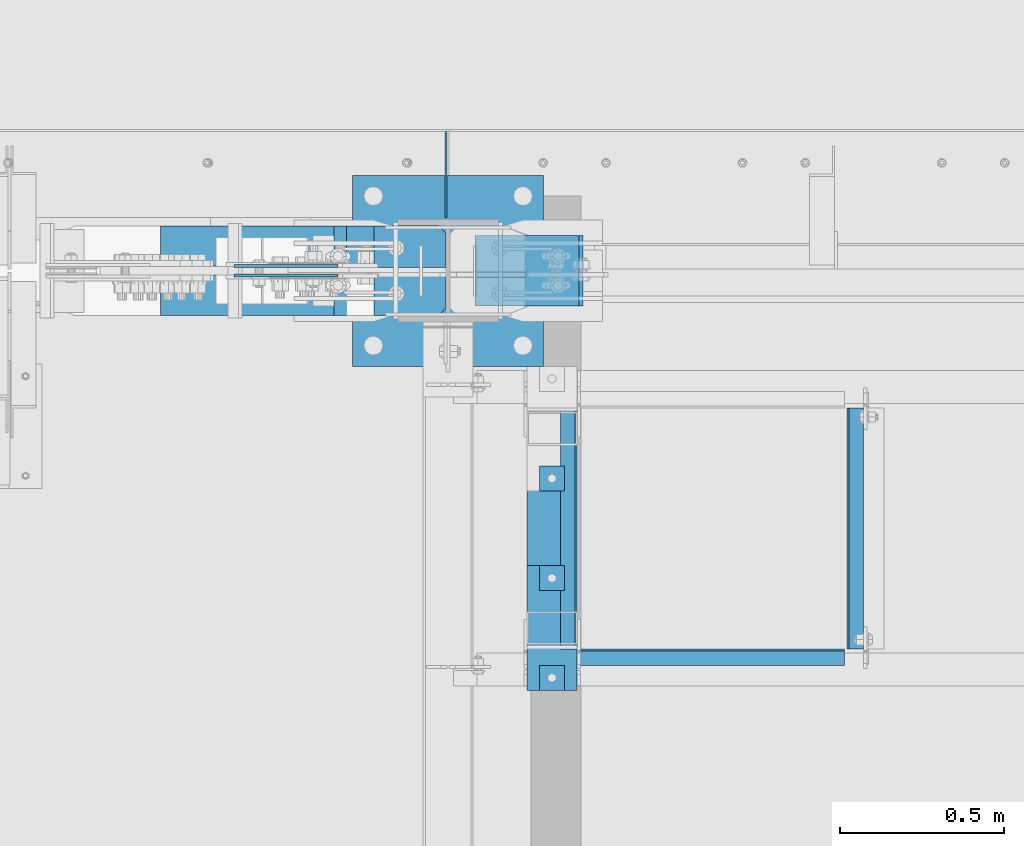
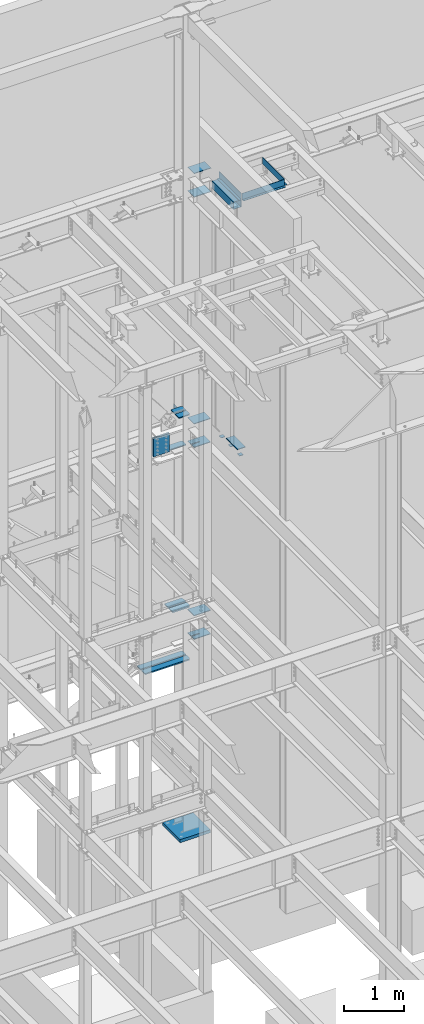
# One storey, part 927 of 1179: 25 beams, 13 elements without a shape of their own.
"""IFC2X3 building model written with IfcOpenShell, lengths in millimetres."""

from ifc_helpers import new_model, si_unit, frame, origin_with_axes, place, context, subcontext, project, spatial, faceted_brep, material, type_object, element, aggregate, save


model = new_model("IFC2X3")

# Units and contexts
model_context = context("Model", 3, precision=1e-05, world=origin_with_axes())
body_context = subcontext(model_context, "Body", "Model", "MODEL_VIEW")
ifc_project = project(units=[si_unit("LENGTHUNIT", "METRE", prefix="MILLI"), si_unit("AREAUNIT", "SQUARE_METRE"), si_unit("VOLUMEUNIT", "CUBIC_METRE"), si_unit("MASSUNIT", "GRAM", prefix="KILO"), si_unit("TIMEUNIT", "SECOND"), si_unit("PLANEANGLEUNIT", "RADIAN"), si_unit("SOLIDANGLEUNIT", "STERADIAN"), si_unit("THERMODYNAMICTEMPERATUREUNIT", "DEGREE_CELSIUS"), si_unit("LUMINOUSINTENSITYUNIT", "LUMEN")], contexts=[model_context])

# Site, building, storey
site_placement = place(None, origin_with_axes())
site = spatial("IfcSite", under=ifc_project, at=site_placement, CompositionType="ELEMENT")
building_placement = place(site_placement, origin_with_axes())
building = spatial("IfcBuilding", under=site, at=building_placement, Name="Undefined", CompositionType="ELEMENT")
storey_placement = place(building_placement, origin_with_axes())
storey = spatial("IfcBuildingStorey", under=building, at=storey_placement, Name="Undefined", CompositionType="ELEMENT", Elevation=0.0)

# Assembly, beam
assembly_1_placement = place(storey_placement, origin_with_axes())
assembly_1 = element("IfcElementAssembly", 1, at=assembly_1_placement, inside=storey, Name="BEAM", AssemblyPlace="NOTDEFINED", PredefinedType="RIGID_FRAME")
ifc_material_1 = material(Name="STEEL/A36")
beam_type_1 = type_object("IfcBeamType", PredefinedType="NOTDEFINED")
beam_1_placement = place(assembly_1_placement, frame((17681.575, 40411.4, 13252.4500061035), z_axis=(0.0, 1.0, 0.0), x_axis=(0.0, 0.0, -1.0)))
beam_1 = element("IfcBeam", 2, at=beam_1_placement, type_object=beam_type_1, material=ifc_material_1, Name="BENT_PLATE", context=body_context, shape_type="Brep", body=[
    faceted_brep([(0.0, -3.17499999999927, -368.300000000003), (0.0, -3.17499999999927, 368.300000000003), (0.0, 3.17499999999927, 368.300000000003), (0.0, 3.17499999999927, -368.300000000003), (133.350006103516, 3.17499999999927, 368.300000000003), (133.350006103516, 3.17499999999927, -368.300000000003), (127.000006103517, -3.17499999999927, -368.300000000003), (127.000006103517, -3.17499999999927, 368.300000000003), (133.350006103516, -47.625, 368.300000000003), (133.350006103516, -47.625, -368.300000000003), (127.000006103517, -47.625, 368.300000000003), (127.000006103517, -47.625, -368.300000000003)], [[[0, 1, 2, 3]], [[3, 2, 4, 5]], [[1, 0, 6, 7]], [[5, 4, 8, 9]], [[4, 2, 1, 7, 10, 8]], [[7, 6, 11, 10]], [[6, 0, 3, 5, 9, 11]], [[10, 11, 9, 8]]]),
])
aggregate(assembly_1, [beam_1])

assembly_2_placement = place(storey_placement, origin_with_axes())
assembly_2 = element("IfcElementAssembly", 3, at=assembly_2_placement, inside=storey, Name="BEAM", AssemblyPlace="NOTDEFINED", PredefinedType="RIGID_FRAME")
beam_2_placement = place(assembly_2_placement, frame((16849.725, 40411.4, 13252.4500061035), z_axis=(0.0, 1.0, 0.0), x_axis=(0.0, 0.0, -1.0)))
beam_2 = element("IfcBeam", 4, at=beam_2_placement, type_object=beam_type_1, material=ifc_material_1, Name="BENT_PLATE", context=body_context, shape_type="Brep", body=[
    faceted_brep([(0.0, -3.17499999999927, -368.300000000003), (0.0, -3.17499999999927, 368.300000000003), (0.0, 3.17499999999927, 368.300000000003), (0.0, 3.17499999999927, -368.300000000003), (127.000006103517, 3.17499999999927, 368.300000000003), (127.000006103517, 3.17499999999927, -368.300000000003), (133.350006103516, -3.17499999999927, -368.300000000003), (133.350006103516, -3.17499999999927, 368.300000000003), (127.000006103517, 47.625, 368.300000000003), (127.000006103517, 47.625, -368.300000000003), (133.350006103516, 47.625, 368.300000000003), (133.350006103516, 47.625, -368.300000000003)], [[[0, 1, 2, 3]], [[3, 2, 4, 5]], [[1, 0, 6, 7]], [[5, 4, 8, 9]], [[4, 2, 1, 7, 10, 8]], [[7, 6, 11, 10]], [[6, 0, 3, 5, 9, 11]], [[10, 11, 9, 8]]]),
])

assembly_3_placement = place(storey_placement, origin_with_axes())
assembly_3 = element("IfcElementAssembly", 5, at=assembly_3_placement, inside=storey, Name="BEAM", AssemblyPlace="NOTDEFINED", PredefinedType="RIGID_FRAME")
beam_3_placement = place(assembly_3_placement, frame((17265.65, 40039.925, 13252.4500061035), z_axis=(1.0, 0.0, 0.0), x_axis=(0.0, 0.0, -1.0)))
beam_3 = element("IfcBeam", 6, at=beam_3_placement, type_object=beam_type_1, material=ifc_material_1, Name="BENT_PLATE", context=body_context, shape_type="Brep", body=[
    faceted_brep([(0.0, -3.17500000000291, -406.400000000001), (0.0, -3.17500000000291, 406.400000000001), (0.0, 3.17500000000291, 406.400000000001), (0.0, 3.17500000000291, -406.400000000001), (133.350006103512, 3.17500000000291, 406.400000000001), (133.350006103512, 3.17500000000291, -406.400000000001), (127.000006103513, -3.17500000000291, -406.400000000001), (127.000006103513, -3.17500000000291, 406.400000000001), (133.350006103512, -47.625, 406.400000000001), (133.350006103512, -47.625, -406.400000000001), (127.000006103513, -47.625, 406.400000000001), (127.000006103513, -47.625, -406.400000000001)], [[[0, 1, 2, 3]], [[3, 2, 4, 5]], [[1, 0, 6, 7]], [[5, 4, 8, 9]], [[4, 2, 1, 7, 10, 8]], [[7, 6, 11, 10]], [[6, 0, 3, 5, 9, 11]], [[10, 11, 9, 8]]]),
])
aggregate(assembly_3, [beam_3])

assembly_4_placement = place(storey_placement, origin_with_axes())
assembly_4 = element("IfcElementAssembly", 7, at=assembly_4_placement, inside=storey, Name="EMBED PLATE", AssemblyPlace="NOTDEFINED", PredefinedType="RIGID_FRAME")
ifc_material_2 = material(Name="STEEL/A572-GR.50")
beam_type_2 = type_object("IfcBeamType", PredefinedType="NOTDEFINED")
beam_4_placement = place(assembly_4_placement, frame((16700.5, 40106.6, 8153.4), z_axis=(0.0, -1.0, 0.0), x_axis=(1.0, 0.0, 0.0)))
beam_4 = element("IfcBeam", 8, at=beam_4_placement, type_object=beam_type_2, material=ifc_material_2, Name="EMBED PLATE", context=body_context, shape_type="Brep", body=[
    faceted_brep([(0.0, 6.35000000000036, -190.5), (0.0, 6.35000000000036, 190.5), (152.400000000001, 6.35000000000036, 190.5), (152.400000000001, 6.35000000000036, -190.5), (0.0, -6.35000000000036, 190.5), (152.400000000001, -6.35000000000036, 190.5), (0.0, -6.35000000000036, -190.5), (152.400000000001, -6.35000000000036, -190.5)], [[[0, 1, 2, 3]], [[1, 4, 5, 2]], [[4, 6, 7, 5]], [[6, 0, 3, 7]], [[5, 7, 3, 2]], [[6, 4, 1, 0]]]),
])
aggregate(assembly_4, [beam_4])

# Assembly, beams
assembly_5_placement = place(storey_placement, origin_with_axes())
assembly_5 = element("IfcElementAssembly", 9, at=assembly_5_placement, inside=storey, Name="COLUMN", AssemblyPlace="NOTDEFINED", PredefinedType="RIGID_FRAME")
beam_type_3 = type_object("IfcBeamType", PredefinedType="NOTDEFINED")
beam_5_placement = place(assembly_5_placement, frame((16541.7500000316, 41198.8, 12646.0249999713), z_axis=(0.0, -1.0, 0.0), x_axis=(1.0, 0.0, 0.0)))
beam_5 = element("IfcBeam", 10, at=beam_5_placement, type_object=beam_type_3, material=ifc_material_2, Name="PLATE", context=body_context, shape_type="Brep", body=[
    faceted_brep([(0.0, 6.35000000000036, -107.949999999997), (0.0, 6.35000000000036, 107.949999999997), (330.200000043667, 6.35000000000036, 107.949999999997), (330.200000043667, 6.35000000000036, -107.949999999997), (0.0, -6.35000000000036, 107.949999999997), (330.200000043667, -6.35000000000036, 107.949999999997), (0.0, -6.35000000000036, -107.949999999997), (330.200000043667, -6.35000000000036, -107.949999999997)], [[[0, 1, 2, 3]], [[1, 4, 5, 2]], [[4, 6, 7, 5]], [[6, 0, 3, 7]], [[5, 7, 3, 2]], [[6, 4, 1, 0]]]),
])
beam_6_placement = place(assembly_5_placement, frame((16541.7500000328, 41198.8, 13125.4499999713), z_axis=(0.0, -1.0, 0.0), x_axis=(1.0, 0.0, 0.0)))
beam_6 = element("IfcBeam", 11, at=beam_6_placement, type_object=beam_type_3, material=ifc_material_2, Name="PLATE", context=body_context, shape_type="Brep", body=[
    faceted_brep([(0.0, 6.35000000000036, -107.949999999997), (0.0, 6.35000000000036, 107.949999999997), (330.200000043667, 6.35000000000036, 107.949999999997), (330.200000043667, 6.35000000000036, -107.949999999997), (0.0, -6.35000000000036, 107.949999999997), (330.200000043667, -6.35000000000036, 107.949999999997), (0.0, -6.35000000000036, -107.949999999997), (330.200000043667, -6.35000000000036, -107.949999999997)], [[[0, 1, 2, 3]], [[1, 4, 5, 2]], [[4, 6, 7, 5]], [[6, 0, 3, 7]], [[5, 7, 3, 2]], [[6, 4, 1, 0]]]),
])
beam_7_placement = place(assembly_5_placement, frame((16541.75, 41198.8, 7540.625), z_axis=(0.0, -1.0, 0.0), x_axis=(1.0, 0.0, 0.0)))
beam_7 = element("IfcBeam", 12, at=beam_7_placement, type_object=beam_type_3, material=ifc_material_2, Name="PLATE", context=body_context, shape_type="Brep", body=[
    faceted_brep([(0.0, -6.35000000000036, 19.8437500550863), (0.0, 6.35000000000036, 19.8437500550863), (150.812499998719, 6.35000000000036, 19.8437500546802), (150.812499998719, -6.35000000000036, 19.8437500546802), (153.850049742483, 6.35000000000036, 19.2395438442423), (153.850049742483, -6.35000000000036, 19.2395438442423), (156.425160073413, 6.35000000000036, 17.5189101313016), (156.425160073413, -6.35000000000036, 17.5189101313016), (158.145793787233, 6.35000000000036, 14.9437998009562), (158.145793787233, -6.35000000000036, 14.9437998009562), (150.812499998683, -6.35000000000036, 3.96875005468019), (150.812499998683, 6.35000000000036, 3.96875005468019), (0.0, 6.35000000000036, 3.96875005508628), (0.0, -6.35000000000036, 3.96875005508628), (153.850049743713, -6.35000000000036, 4.57295626562569), (153.850049743713, 6.35000000000036, 4.57295626562569), (156.42516007532, -6.35000000000036, 6.29358997996519), (156.42516007532, 6.35000000000036, 6.29358997996519), (158.14579378879, -6.35000000000036, 8.8687003121604), (158.14579378879, 6.35000000000036, 8.8687003121604), (158.749999998705, -6.35000000000036, 11.9062500573978), (158.749999998705, 6.35000000000036, 11.9062500573978), (0.0, 6.35000000000036, 107.949999999997), (0.0, -6.35000000000036, 107.949999999997), (317.5, -6.35000000000036, 107.949999999997), (317.5, 6.35000000000036, 107.949999999997), (317.5, -6.35000000000036, -107.949999999997), (317.5, 6.35000000000036, -107.949999999997), (0.0, -6.35000000000036, -107.949999999997), (0.0, 6.35000000000036, -107.949999999997)], [[[0, 1, 2, 3]], [[3, 2, 4, 5]], [[5, 4, 6, 7]], [[7, 6, 8, 9]], [[10, 11, 12, 13]], [[14, 15, 11, 10]], [[16, 17, 15, 14]], [[18, 19, 17, 16]], [[20, 21, 19, 18]], [[9, 8, 21, 20]], [[22, 23, 24, 25]], [[24, 26, 27, 25]], [[28, 29, 27, 26]], [[29, 28, 13, 12]], [[6, 4, 2, 1, 22, 25, 27, 29, 12, 11, 15, 17, 19, 21, 8]], [[23, 22, 1, 0]], [[16, 14, 10, 13, 28, 26, 24, 23, 0, 3, 5, 7, 9, 20, 18]]]),
])
beam_8_placement = place(assembly_5_placement, frame((16541.75, 41198.8, 8020.05), z_axis=(0.0, -1.0, 0.0), x_axis=(1.0, 0.0, 0.0)))
beam_8 = element("IfcBeam", 13, at=beam_8_placement, type_object=beam_type_3, material=ifc_material_2, Name="PLATE", context=body_context, shape_type="Brep", body=[
    faceted_brep([(0.0, 6.35000000000036, -107.949999999997), (0.0, 6.35000000000036, 107.949999999997), (317.5, 6.35000000000036, 107.949999999997), (317.5, 6.35000000000036, -107.949999999997), (0.0, -6.35000000000036, 107.949999999997), (317.5, -6.35000000000036, 107.949999999997), (0.0, -6.35000000000036, -107.949999999997), (317.5, -6.35000000000036, -107.949999999997)], [[[0, 1, 2, 3]], [[1, 4, 5, 2]], [[4, 6, 7, 5]], [[6, 0, 3, 7]], [[5, 7, 3, 2]], [[6, 4, 1, 0]]]),
])
beam_9_placement = place(assembly_5_placement, frame((16541.75, 41198.8, 3629.025), z_axis=(0.0, -1.0, 0.0), x_axis=(1.0, 0.0, 0.0)))
beam_9 = element("IfcBeam", 14, at=beam_9_placement, type_object=beam_type_3, material=ifc_material_2, Name="PLATE", context=body_context, shape_type="Brep", body=[
    faceted_brep([(0.0, -6.35000000000036, 19.8437500550863), (0.0, 6.35000000000036, 19.8437500550863), (150.812499998719, 6.35000000000036, 19.8437500546802), (150.812499998719, -6.35000000000036, 19.8437500546802), (153.850049742483, 6.35000000000036, 19.2395438442423), (153.850049742483, -6.35000000000036, 19.2395438442423), (156.425160073413, 6.35000000000036, 17.5189101313016), (156.425160073413, -6.35000000000036, 17.5189101313016), (158.145793787233, 6.35000000000036, 14.9437998009562), (158.145793787233, -6.35000000000036, 14.9437998009562), (150.812499998683, -6.35000000000036, 3.96875005468019), (150.812499998683, 6.35000000000036, 3.96875005468019), (0.0, 6.35000000000036, 3.96875005508628), (0.0, -6.35000000000036, 3.96875005508628), (153.850049743713, -6.35000000000036, 4.57295626562569), (153.850049743713, 6.35000000000036, 4.57295626562569), (156.42516007532, -6.35000000000036, 6.29358997996519), (156.42516007532, 6.35000000000036, 6.29358997996519), (158.14579378879, -6.35000000000036, 8.8687003121604), (158.14579378879, 6.35000000000036, 8.8687003121604), (158.749999998705, -6.35000000000036, 11.9062500573978), (158.749999998705, 6.35000000000036, 11.9062500573978), (0.0, 6.35000000000036, 107.949999999997), (0.0, -6.35000000000036, 107.949999999997), (317.5, -6.35000000000036, 107.949999999997), (317.5, 6.35000000000036, 107.949999999997), (317.5, -6.35000000000036, -107.949999999997), (317.5, 6.35000000000036, -107.949999999997), (0.0, -6.35000000000036, -107.949999999997), (0.0, 6.35000000000036, -107.949999999997)], [[[0, 1, 2, 3]], [[3, 2, 4, 5]], [[5, 4, 6, 7]], [[7, 6, 8, 9]], [[10, 11, 12, 13]], [[14, 15, 11, 10]], [[16, 17, 15, 14]], [[18, 19, 17, 16]], [[20, 21, 19, 18]], [[9, 8, 21, 20]], [[22, 23, 24, 25]], [[24, 26, 27, 25]], [[28, 29, 27, 26]], [[29, 28, 13, 12]], [[6, 4, 2, 1, 22, 25, 27, 29, 12, 11, 15, 17, 19, 21, 8]], [[23, 22, 1, 0]], [[16, 14, 10, 13, 28, 26, 24, 23, 0, 3, 5, 7, 9, 20, 18]]]),
])
beam_10_placement = place(assembly_5_placement, frame((16541.75, 41198.8, 4108.45), z_axis=(0.0, -1.0, 0.0), x_axis=(1.0, 0.0, 0.0)))
beam_10 = element("IfcBeam", 15, at=beam_10_placement, type_object=beam_type_3, material=ifc_material_2, Name="PLATE", context=body_context, shape_type="Brep", body=[
    faceted_brep([(0.0, 6.35000000000036, -107.949999999997), (0.0, 6.35000000000036, 107.949999999997), (317.5, 6.35000000000036, 107.949999999997), (317.5, 6.35000000000036, -107.949999999997), (0.0, -6.35000000000036, 107.949999999997), (317.5, -6.35000000000036, 107.949999999997), (0.0, -6.35000000000036, -107.949999999997), (317.5, -6.35000000000036, -107.949999999997)], [[[0, 1, 2, 3]], [[1, 4, 5, 2]], [[4, 6, 7, 5]], [[6, 0, 3, 7]], [[5, 7, 3, 2]], [[6, 4, 1, 0]]]),
])
beam_type_4 = type_object("IfcBeamType", PredefinedType="NOTDEFINED")
beam_11_placement = place(assembly_5_placement, frame((16148.0499999994, 41271.825, 7556.5), z_axis=(0.0, 1.0, 0.0), x_axis=(1.0, 0.0, 0.0)))
beam_11 = element("IfcBeam", 16, at=beam_11_placement, type_object=beam_type_4, material=ifc_material_2, Name="PLATE", context=body_context, shape_type="Brep", body=[
    faceted_brep([(304.800000000001, 9.52499999999964, 41.2750000000015), (282.575000000003, 9.52499999999964, 63.5), (282.575000000003, -9.52499999999964, 63.5), (304.800000000001, -9.52499999999964, 41.2750000000015), (304.800000000001, 9.52499999999964, -63.5), (0.0, 9.52500000000146, -63.5), (0.0, 9.52500000000146, 63.5), (0.0, -9.52500000000146, 63.5), (0.0, -9.52500000000146, -63.5), (304.800000000001, -9.52499999999964, -63.5)], [[[0, 1, 2, 3]], [[4, 5, 6, 1, 0]], [[6, 7, 2, 1]], [[7, 8, 9, 3, 2]], [[8, 5, 4, 9]], [[9, 4, 0, 3]], [[8, 7, 6, 5]]]),
])
beam_12_placement = place(assembly_5_placement, frame((16232.5906748554, 41125.775, 8263.92332782742), z_axis=(0.0, -1.0, 0.0), x_axis=(1.0, 0.0, 0.0)))
beam_12 = element("IfcBeam", 17, at=beam_12_placement, type_object=beam_type_4, material=ifc_material_2, Name="PLATE", context=body_context, shape_type="Brep", body=[
    faceted_brep([(220.259325144028, 9.52499999999964, 41.2750000000015), (198.03432514403, 9.52499999999964, 63.5), (198.03432514403, -9.52499999999964, 63.5), (220.259325144028, -9.52499999999964, 41.2750000000015), (220.259325144028, 9.52499999999964, -63.5), (0.0, 9.52500000000146, -63.5), (0.0, 9.52500000000146, 63.5), (0.0, -9.52500000000146, 63.5), (0.0, -9.52500000000146, -63.5), (220.259325144028, -9.52499999999964, -63.5)], [[[0, 1, 2, 3]], [[4, 5, 6, 1, 0]], [[6, 7, 2, 1]], [[7, 8, 9, 3, 2]], [[8, 5, 4, 9]], [[9, 4, 0, 3]], [[8, 7, 6, 5]]]),
])
beam_13_placement = place(assembly_5_placement, frame((16232.5906748554, 41271.825, 8263.92332782742), z_axis=(0.0, 1.0, 0.0), x_axis=(1.0, 0.0, 0.0)))
beam_13 = element("IfcBeam", 18, at=beam_13_placement, type_object=beam_type_4, material=ifc_material_2, Name="PLATE", context=body_context, shape_type="Brep", body=[
    faceted_brep([(220.259325144028, 9.52499999999964, 41.2750000000015), (198.03432514403, 9.52499999999964, 63.5), (198.03432514403, -9.52499999999964, 63.5), (220.259325144028, -9.52499999999964, 41.2750000000015), (220.259325144028, 9.52499999999964, -63.5), (0.0, 9.52500000000146, -63.5), (0.0, 9.52500000000146, 63.5), (0.0, -9.52500000000146, 63.5), (0.0, -9.52500000000146, -63.5), (220.259325144028, -9.52499999999964, -63.5)], [[[0, 1, 2, 3]], [[4, 5, 6, 1, 0]], [[6, 7, 2, 1]], [[7, 8, 9, 3, 2]], [[8, 5, 4, 9]], [[9, 4, 0, 3]], [[8, 7, 6, 5]]]),
])

# Assembly, beam
assembly_6_placement = place(storey_placement, origin_with_axes())
assembly_6 = element("IfcElementAssembly", 19, at=assembly_6_placement, inside=storey, Name="BEAM", AssemblyPlace="NOTDEFINED", PredefinedType="RIGID_FRAME")
beam_type_5 = type_object("IfcBeamType", PredefinedType="NOTDEFINED")
beam_14_placement = place(assembly_6_placement, frame((16452.8500000005, 41362.3124999949, 8083.55000610352), z_axis=(0.0, 0.0, 1.0), x_axis=(0.0, 1.0, 0.0)))
beam_14 = element("IfcBeam", 20, at=beam_14_placement, type_object=beam_type_5, material=ifc_material_1, Name="PLATE", context=body_context, shape_type="Brep", body=[
    faceted_brep([(261.937500000007, -3.17500000000001, -44.4500000000007), (242.887500000004, -3.17500000000001, -63.5), (242.887500000004, 3.17500000000001, -63.5), (261.937500000007, 3.17500000000001, -44.4500000000007), (0.0, 3.17499999999927, -63.5), (0.0, 3.17499999999927, 63.5), (261.937500000007, 3.17500000000001, 63.5), (0.0, -3.17499999999927, 63.5), (261.937500000007, -3.17500000000001, 63.5), (0.0, -3.17499999999927, -63.5)], [[[0, 1, 2, 3]], [[4, 5, 6, 3, 2]], [[5, 7, 8, 6]], [[8, 7, 9, 1, 0]], [[9, 4, 2, 1]], [[6, 8, 0, 3]], [[9, 7, 5, 4]]]),
])
aggregate(assembly_6, [beam_14])

assembly_7_placement = place(storey_placement, origin_with_axes())
assembly_7 = element("IfcElementAssembly", 21, at=assembly_7_placement, inside=storey, Name="PLATE", AssemblyPlace="NOTDEFINED", PredefinedType="RIGID_FRAME")
beam_type_6 = type_object("IfcBeamType", PredefinedType="NOTDEFINED")
beam_15_placement = place(assembly_7_placement, frame((16452.8508052372, 41123.3935, 3269.48771062712), z_axis=(0.0, 1.0, 0.0), x_axis=(-1.0, 0.0, 0.0)))
beam_15 = element("IfcBeam", 22, at=beam_15_placement, type_object=beam_type_6, material=ifc_material_2, Name="PLATE", context=body_context, shape_type="Brep", body=[
    faceted_brep([(22.2249999999985, -12.6999999999998, -61.1189999999997), (0.0, -12.6999999999998, -38.8940000000002), (0.0, 12.6999999999998, -38.8940000000002), (22.2249999999985, 12.6999999999998, -61.1189999999997), (0.0, 12.7, 61.1189999999988), (873.039458857706, 12.6999999999998, 61.1189999999988), (873.039458857706, 12.6999999999998, -61.1189999999988), (0.0, -12.7, 61.1189999999988), (873.039458857706, -12.6999999999998, 61.1189999999988), (873.039458857706, -12.6999999999998, -61.1189999999988)], [[[0, 1, 2, 3]], [[4, 5, 6, 3, 2]], [[4, 7, 8, 5]], [[9, 8, 7, 1, 0]], [[6, 9, 0, 3]], [[8, 9, 6, 5]], [[7, 4, 2, 1]]]),
])
aggregate(assembly_7, [beam_15])

assembly_8_placement = place(storey_placement, origin_with_axes())
assembly_8 = element("IfcElementAssembly", 23, at=assembly_8_placement, inside=storey, Name="PLATE", AssemblyPlace="NOTDEFINED", PredefinedType="RIGID_FRAME")
beam_16_placement = place(assembly_8_placement, frame((16452.8508052372, 41274.2065, 3269.48771062712), z_axis=(0.0, -1.0, 0.0), x_axis=(-1.0, 0.0, 0.0)))
beam_16 = element("IfcBeam", 24, at=beam_16_placement, type_object=beam_type_6, material=ifc_material_2, Name="PLATE", context=body_context, shape_type="Brep", body=[
    faceted_brep([(22.2249999999985, -12.6999999999998, -61.1189999999997), (0.0, -12.6999999999998, -38.8940000000002), (0.0, 12.6999999999998, -38.8940000000002), (22.2249999999985, 12.6999999999998, -61.1189999999997), (0.0, 12.7, 61.1189999999988), (873.039458857706, 12.6999999999998, 61.1189999999988), (873.039458857706, 12.6999999999998, -61.1189999999988), (0.0, -12.7, 61.1189999999988), (873.039458857706, -12.6999999999998, 61.1189999999988), (873.039458857706, -12.6999999999998, -61.1189999999988)], [[[0, 1, 2, 3]], [[4, 5, 6, 3, 2]], [[4, 7, 8, 5]], [[9, 8, 7, 1, 0]], [[6, 9, 0, 3]], [[8, 9, 6, 5]], [[7, 4, 2, 1]]]),
])
aggregate(assembly_8, [beam_16])

# Beam
beam_17_placement = place(assembly_5_placement, frame((16452.8508052832, 41123.3935, 4347.84110103117), z_axis=(0.0, 1.0, 0.0), x_axis=(-1.0, 0.0, 0.0)))
beam_17 = element("IfcBeam", 25, at=beam_17_placement, type_object=beam_type_6, material=ifc_material_2, Name="PLATE", context=body_context, shape_type="Brep", body=[
    faceted_brep([(22.2249999999985, -12.6999999999998, -61.1189999999997), (0.0, -12.6999999999998, -38.8940000000002), (0.0, 12.6999999999998, -38.8940000000002), (22.2249999999985, 12.6999999999998, -61.1189999999997), (0.0, 12.7, 61.1189999999988), (342.342939159009, 12.6999999999998, 61.1189999999988), (342.342939159009, 12.6999999999998, -61.1189999999988), (0.0, -12.7, 61.1189999999988), (342.342939159009, -12.6999999999998, 61.1189999999988), (342.342939159009, -12.6999999999998, -61.1189999999988)], [[[0, 1, 2, 3]], [[4, 5, 6, 3, 2]], [[4, 7, 8, 5]], [[9, 8, 7, 1, 0]], [[6, 9, 0, 3]], [[8, 9, 6, 5]], [[7, 4, 2, 1]]]),
])

beam_18_placement = place(assembly_5_placement, frame((16452.8508052832, 41274.2065, 4347.84110103117), z_axis=(0.0, -1.0, 0.0), x_axis=(-1.0, 0.0, 0.0)))
beam_18 = element("IfcBeam", 26, at=beam_18_placement, type_object=beam_type_6, material=ifc_material_2, Name="PLATE", context=body_context, shape_type="Brep", body=[
    faceted_brep([(22.2249999999985, -12.6999999999998, -61.1189999999997), (0.0, -12.6999999999998, -38.8940000000002), (0.0, 12.6999999999998, -38.8940000000002), (22.2249999999985, 12.6999999999998, -61.1189999999997), (0.0, 12.7, 61.1189999999988), (342.342939159009, 12.6999999999998, 61.1189999999988), (342.342939159009, 12.6999999999998, -61.1189999999988), (0.0, -12.7, 61.1189999999988), (342.342939159009, -12.6999999999998, 61.1189999999988), (342.342939159009, -12.6999999999998, -61.1189999999988)], [[[0, 1, 2, 3]], [[4, 5, 6, 3, 2]], [[4, 7, 8, 5]], [[9, 8, 7, 1, 0]], [[6, 9, 0, 3]], [[8, 9, 6, 5]], [[7, 4, 2, 1]]]),
])

# Assembly, beam
assembly_9_placement = place(storey_placement, origin_with_axes())
assembly_9 = element("IfcElementAssembly", 27, at=assembly_9_placement, inside=storey, Name="PLATE", AssemblyPlace="NOTDEFINED", PredefinedType="RIGID_FRAME")
beam_type_7 = type_object("IfcBeamType", PredefinedType="NOTDEFINED")
beam_19_placement = place(assembly_9_placement, frame((16122.3534855108, 41184.5127863882, 7739.06051692846), z_axis=(0.0, 0.0, -1.0), x_axis=(-1.0, 0.0, 0.0)))
beam_19 = element("IfcBeam", 28, at=beam_19_placement, type_object=beam_type_7, material=ifc_material_2, Name="PLATE", context=body_context, shape_type="Brep", body=[
    faceted_brep([(0.0, 4.76249999999709, -190.5), (0.0, 4.76249999999709, 190.5), (317.499999999995, 4.76250000000073, 190.500000000051), (317.500000000042, 4.76250000000073, -190.499999999973), (0.0, -4.76249999999709, 190.5), (317.499999999995, -4.76250000000073, 190.500000000051), (0.0, -4.76249999999709, -190.5), (317.500000000042, -4.76250000000073, -190.499999999973)], [[[0, 1, 2, 3]], [[1, 4, 5, 2]], [[4, 6, 7, 5]], [[6, 0, 3, 7]], [[5, 7, 3, 2]], [[6, 4, 1, 0]]]),
])
aggregate(assembly_9, [beam_19])

assembly_10_placement = place(storey_placement, origin_with_axes())
assembly_10 = element("IfcElementAssembly", 29, at=assembly_10_placement, inside=storey, Name="PLATE", AssemblyPlace="NOTDEFINED", PredefinedType="RIGID_FRAME")
beam_20_placement = place(assembly_10_placement, frame((15804.8535967904, 41213.0872136118, 7739.0625), z_axis=(0.0, 0.0, -1.0), x_axis=(1.0, 0.0, 0.0)))
beam_20 = element("IfcBeam", 30, at=beam_20_placement, type_object=beam_type_7, material=ifc_material_2, Name="PLATE", context=body_context, shape_type="Brep", body=[
    faceted_brep([(0.0, 4.76249999999709, -190.5), (0.0, 4.76249999999709, 190.5), (317.499999999995, 4.76250000000073, 190.500000000051), (317.500000000042, 4.76250000000073, -190.499999999973), (0.0, -4.76249999999709, 190.5), (317.499999999995, -4.76250000000073, 190.500000000051), (0.0, -4.76249999999709, -190.5), (317.500000000042, -4.76250000000073, -190.499999999973)], [[[0, 1, 2, 3]], [[1, 4, 5, 2]], [[4, 6, 7, 5]], [[6, 0, 3, 7]], [[5, 7, 3, 2]], [[6, 4, 1, 0]]]),
])
aggregate(assembly_10, [beam_20])

assembly_11_placement = place(storey_placement, origin_with_axes())
assembly_11 = element("IfcElementAssembly", 31, at=assembly_11_placement, inside=storey, Name="PLATE", AssemblyPlace="NOTDEFINED", PredefinedType="RIGID_FRAME")
beam_type_8 = type_object("IfcBeamType", PredefinedType="NOTDEFINED")
beam_21_placement = place(assembly_11_placement, frame((16738.6, 39954.2, 8008.9375), z_axis=(0.0, -1.0, 0.0), x_axis=(1.0, 0.0, 0.0)))
beam_21 = element("IfcBeam", 32, at=beam_21_placement, type_object=beam_type_8, material=ifc_material_1, Name="PLATE", context=body_context, shape_type="Brep", body=[
    faceted_brep([(1.81898940354586e-12, 4.76249999999891, -38.0999999999985), (0.0, 4.76250000000073, 38.0999999999985), (76.2000000000007, 4.76249999999982, 38.0999999999985), (76.2000000000007, 4.76249999999982, -38.0999999999985), (0.0, -4.76250000000073, 38.0999999999985), (76.2000000000007, -4.76249999999982, 38.0999999999985), (-9.09494701772928e-13, -4.76250000000073, -38.0999999999985), (76.2000000000007, -4.76249999999982, -38.0999999999985)], [[[0, 1, 2, 3]], [[1, 4, 5, 2]], [[4, 6, 7, 5]], [[6, 0, 3, 7]], [[5, 7, 3, 2]], [[6, 4, 1, 0]]]),
])
aggregate(assembly_11, [beam_21])

assembly_12_placement = place(storey_placement, origin_with_axes())
assembly_12 = element("IfcElementAssembly", 33, at=assembly_12_placement, inside=storey, Name="PLATE", AssemblyPlace="NOTDEFINED", PredefinedType="RIGID_FRAME")
beam_22_placement = place(assembly_12_placement, frame((16738.6, 40259.0, 8008.9375), z_axis=(0.0, -1.0, 0.0), x_axis=(1.0, 0.0, 0.0)))
beam_22 = element("IfcBeam", 34, at=beam_22_placement, type_object=beam_type_8, material=ifc_material_1, Name="PLATE", context=body_context, shape_type="Brep", body=[
    faceted_brep([(1.81898940354586e-12, 4.76249999999891, -38.0999999999985), (0.0, 4.76250000000073, 38.0999999999985), (76.2000000000007, 4.76249999999982, 38.0999999999985), (76.2000000000007, 4.76249999999982, -38.0999999999985), (0.0, -4.76250000000073, 38.0999999999985), (76.2000000000007, -4.76249999999982, 38.0999999999985), (-9.09494701772928e-13, -4.76250000000073, -38.0999999999985), (76.2000000000007, -4.76249999999982, -38.0999999999985)], [[[0, 1, 2, 3]], [[1, 4, 5, 2]], [[4, 6, 7, 5]], [[6, 0, 3, 7]], [[5, 7, 3, 2]], [[6, 4, 1, 0]]]),
])
aggregate(assembly_12, [beam_22])

assembly_13_placement = place(storey_placement, origin_with_axes())
assembly_13 = element("IfcElementAssembly", 35, at=assembly_13_placement, inside=storey, Name="PLATE", AssemblyPlace="NOTDEFINED", PredefinedType="RIGID_FRAME")
beam_23_placement = place(assembly_13_placement, frame((16738.6, 40563.8, 8008.9375), z_axis=(0.0, -1.0, 0.0), x_axis=(1.0, 0.0, 0.0)))
beam_23 = element("IfcBeam", 36, at=beam_23_placement, type_object=beam_type_8, material=ifc_material_1, Name="PLATE", context=body_context, shape_type="Brep", body=[
    faceted_brep([(1.81898940354586e-12, 4.76249999999891, -38.0999999999985), (0.0, 4.76250000000073, 38.0999999999985), (76.2000000000007, 4.76249999999982, 38.0999999999985), (76.2000000000007, 4.76249999999982, -38.0999999999985), (0.0, -4.76250000000073, 38.0999999999985), (76.2000000000007, -4.76249999999982, 38.0999999999985), (-9.09494701772928e-13, -4.76250000000073, -38.0999999999985), (76.2000000000007, -4.76249999999982, -38.0999999999985)], [[[0, 1, 2, 3]], [[1, 4, 5, 2]], [[4, 6, 7, 5]], [[6, 0, 3, 7]], [[5, 7, 3, 2]], [[6, 4, 1, 0]]]),
])
aggregate(assembly_13, [beam_23])

# Beam
ifc_material_3 = material()
beam_type_9 = type_object("IfcBeamType", Name="HSS6X6X3/16", PredefinedType="NOTDEFINED")
beam_24_placement = place(assembly_2_placement, frame((16776.7, 40043.1, 13042.9), z_axis=(0.0, 0.0, 1.0), x_axis=(0.0, 1.0, 0.0)))
beam_24 = element("IfcBeam", 37, at=beam_24_placement, type_object=beam_type_9, material=ifc_material_3, Name="BEAM", ObjectType="HSS6X6X3/16", context=body_context, shape_type="Brep", body=[
    faceted_brep([(9.52499999999418, 71.4375, -71.4375), (9.52499999999418, -71.4375, -71.4375), (726.312999999995, -71.4375, -71.4375), (726.312999999995, 71.4375, -71.4375), (9.52499999999418, -71.4375, 71.4375), (726.312999999995, -71.4375, 71.4375), (9.52499999999418, 71.4375, 71.4375), (726.312999999995, 71.4375, 71.4375), (9.52499999999998, 76.1999999999971, -76.1999999999998), (9.52499999999998, 76.1999999999971, 76.1999999999998), (726.312999999995, 76.2000000000007, 76.2000000000007), (726.312999999995, 76.2000000000007, -76.2000000000007), (9.52499999999998, -76.1999999999971, 76.1999999999998), (726.312999999995, -76.2000000000007, 76.2000000000007), (9.52499999999998, -76.1999999999971, -76.1999999999998), (726.312999999995, -76.2000000000007, -76.2000000000007)], [[[0, 1, 2, 3]], [[1, 4, 5, 2]], [[4, 6, 7, 5]], [[6, 0, 3, 7]], [[8, 9, 10, 11]], [[9, 12, 13, 10]], [[12, 14, 15, 13]], [[14, 8, 11, 15]], [[13, 15, 11, 10], [5, 7, 3, 2]], [[14, 12, 9, 8], [6, 4, 1, 0]]]),
])

aggregate(assembly_2, [beam_2, beam_24])

beam_type_10 = type_object("IfcBeamType", PredefinedType="NOTDEFINED")
beam_25_placement = place(assembly_5_placement, frame((16167.10050354, 41198.8, -247.65), z_axis=(0.0, 1.0, 0.0), x_axis=(1.0, 0.0, 0.0)))
beam_25 = element("IfcBeam", 38, at=beam_25_placement, type_object=beam_type_10, material=ifc_material_2, context=body_context, shape_type="Brep", body=[
    faceted_brep([(0.0, 31.75, -292.1), (0.0, 31.75, 292.1), (584.199496459958, 31.75, 292.1), (584.199496459958, 31.75, -292.1), (0.0, -31.75, 292.1), (584.199496459958, -31.75, 292.1), (0.0, -31.75, -292.1), (584.199496459958, -31.75, -292.1)], [[[0, 1, 2, 3]], [[1, 4, 5, 2]], [[4, 6, 7, 5]], [[6, 0, 3, 7]], [[5, 7, 3, 2]], [[6, 4, 1, 0]]]),
])

aggregate(assembly_5, [beam_11, beam_12, beam_13, beam_17, beam_18, beam_5, beam_6, beam_7, beam_8, beam_9, beam_10, beam_25])

save(model, "model.ifc")
